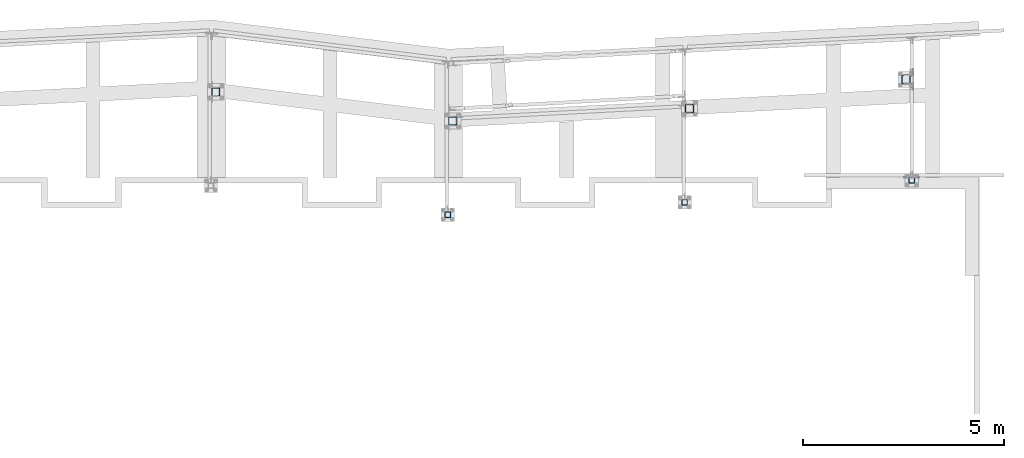
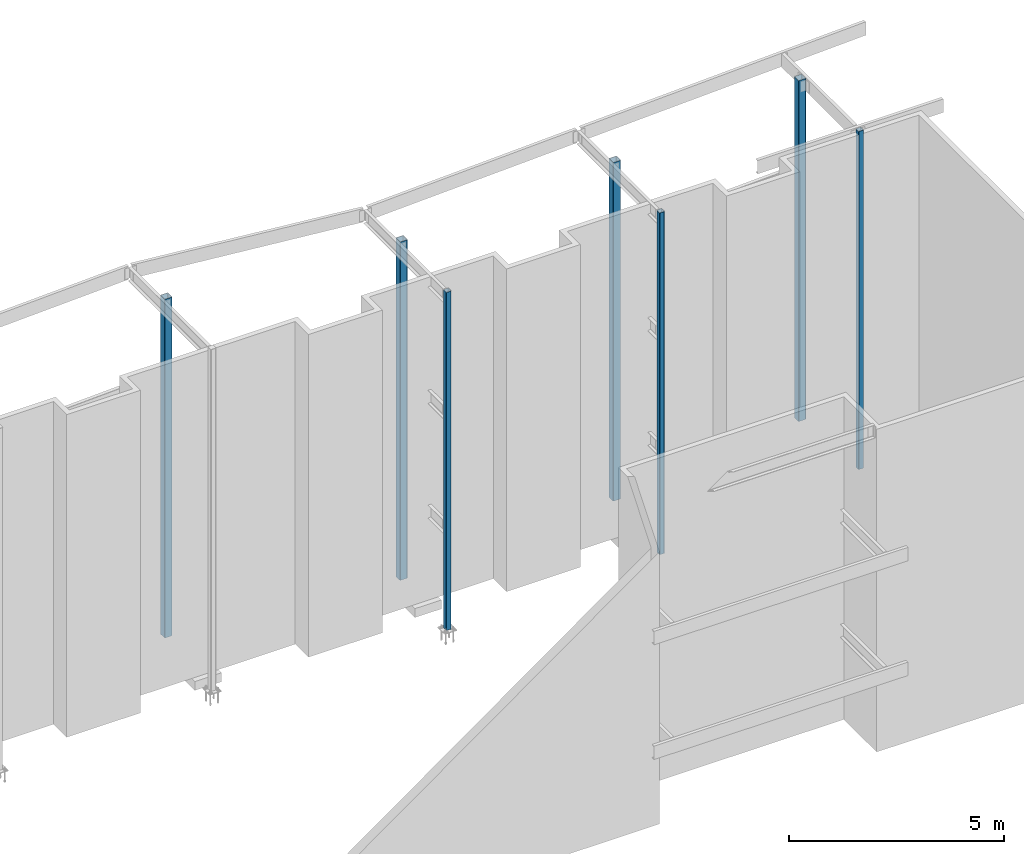
# One storey, part 2 of 89: 7 columns.
"""IFC4 building model written with IfcOpenShell, lengths in feet."""

from ifc_helpers import new_model, entity, si_unit, converted_unit, derived_unit, direction, frame, origin, place, context, subcontext, project, spatial, polyline, outline, extrude, boolean, source, transform, mapped, material, type_object, type_shapes, element, save


model = new_model("IFC4")

# Units and contexts
model_context = context("Model", 3, precision=0.0001, world=origin(), true_north=direction((6.12303176911189e-17, 1.0)))
body_context = subcontext(model_context, "Body", "Model", "MODEL_VIEW")
ifc_project = project(units=[converted_unit("LENGTHUNIT", "FOOT", entity("IfcRatioMeasure", 0.3048), si_unit("LENGTHUNIT", "METRE"), dimensions=[1, 0, 0, 0, 0, 0, 0]), converted_unit("AREAUNIT", "SQUARE FOOT", entity("IfcRatioMeasure", 0.09290304), si_unit("AREAUNIT", "SQUARE_METRE"), dimensions=[2, 0, 0, 0, 0, 0, 0]), converted_unit("VOLUMEUNIT", "CUBIC FOOT", entity("IfcRatioMeasure", 0.028316846592), si_unit("VOLUMEUNIT", "CUBIC_METRE"), dimensions=[3, 0, 0, 0, 0, 0, 0]), si_unit("PLANEANGLEUNIT", "RADIAN"), si_unit("MASSUNIT", "GRAM", prefix="KILO"), derived_unit("MASSDENSITYUNIT", [(si_unit("MASSUNIT", "GRAM", prefix="KILO"), 1), (si_unit("LENGTHUNIT", "METRE"), -3)]), derived_unit("MOMENTOFINERTIAUNIT", [(si_unit("LENGTHUNIT", "METRE"), 4)]), si_unit("TIMEUNIT", "SECOND"), si_unit("FREQUENCYUNIT", "HERTZ"), si_unit("THERMODYNAMICTEMPERATUREUNIT", "DEGREE_CELSIUS"), derived_unit("THERMALTRANSMITTANCEUNIT", [(si_unit("MASSUNIT", "GRAM", prefix="KILO"), 1), (si_unit("THERMODYNAMICTEMPERATUREUNIT", "KELVIN"), -1), (si_unit("TIMEUNIT", "SECOND"), -3)]), derived_unit("VOLUMETRICFLOWRATEUNIT", [(si_unit("LENGTHUNIT", "METRE"), 3), (si_unit("TIMEUNIT", "SECOND"), -1)]), si_unit("ELECTRICCURRENTUNIT", "AMPERE"), si_unit("ELECTRICVOLTAGEUNIT", "VOLT"), si_unit("POWERUNIT", "WATT"), si_unit("FORCEUNIT", "NEWTON"), si_unit("ILLUMINANCEUNIT", "LUX"), si_unit("LUMINOUSFLUXUNIT", "LUMEN"), si_unit("LUMINOUSINTENSITYUNIT", "CANDELA"), derived_unit("USERDEFINED", [(si_unit("MASSUNIT", "GRAM", prefix="KILO"), -1), (si_unit("LENGTHUNIT", "METRE"), -2), (si_unit("TIMEUNIT", "SECOND"), 3), (si_unit("LUMINOUSFLUXUNIT", "LUMEN"), 1)]), derived_unit("LINEARVELOCITYUNIT", [(si_unit("LENGTHUNIT", "METRE"), 1), (si_unit("TIMEUNIT", "SECOND"), -1)]), si_unit("PRESSUREUNIT", "PASCAL"), derived_unit("USERDEFINED", [(si_unit("LENGTHUNIT", "METRE"), -2), (si_unit("MASSUNIT", "GRAM", prefix="KILO"), 1), (si_unit("TIMEUNIT", "SECOND"), -2)]), derived_unit("LINEARFORCEUNIT", [(si_unit("MASSUNIT", "GRAM", prefix="KILO"), 1), (si_unit("LENGTHUNIT", "METRE"), 1), (si_unit("TIMEUNIT", "SECOND"), -2), (si_unit("LENGTHUNIT", "METRE"), -1)]), derived_unit("PLANARFORCEUNIT", [(si_unit("MASSUNIT", "GRAM", prefix="KILO"), 1), (si_unit("LENGTHUNIT", "METRE"), 1), (si_unit("TIMEUNIT", "SECOND"), -2), (si_unit("LENGTHUNIT", "METRE"), -2)])], contexts=[model_context])

# Site, building, storey
site_placement = place(None, origin())
site = spatial("IfcSite", under=ifc_project, at=site_placement, CompositionType="ELEMENT")
building_placement = place(site_placement, frame((-472.238160486, -49.138065117, 0.0)))
building = spatial("IfcBuilding", under=site, at=building_placement, CompositionType="ELEMENT")
storey_placement = place(building_placement, origin())
storey = spatial("IfcBuildingStorey", under=building, at=storey_placement, Name="Level 1", CompositionType="ELEMENT", Elevation=0.0)

# Columns
ifc_material = material(Name="Color 7719", Category="Materials")
column_type_1 = type_object("IfcColumnType", Name="hss15", PredefinedType="COLUMN")
shared_shape_1 = source(origin(), body_context, "Body", "CSG", [
    boolean("DIFFERENCE", extrude(outline(polyline([(-0.166666666666629, -0.229166666666686), (0.166666666666629, -0.229166666666686), (0.190584381189524, -0.224409137448617), (0.210860840490795, -0.210860840490852), (0.224409137448674, -0.190584381189467), (0.229166666666629, -0.166666666666686), (0.229166666666629, 0.166666666666686), (0.224409137448674, 0.190584381189467), (0.210860840490795, 0.210860840490852), (0.190584381189524, 0.224409137448617), (0.166666666666629, 0.229166666666686), (-0.166666666666629, 0.229166666666686), (-0.190584381189524, 0.224409137448617), (-0.210860840490795, 0.210860840490852), (-0.224409137448674, 0.190584381189467), (-0.229166666666629, 0.166666666666686), (-0.229166666666629, -0.166666666666686), (-0.224409137448674, -0.190584381189467), (-0.210860840490795, -0.210860840490852), (-0.190584381189524, -0.224409137448617), (-0.166666666666629, -0.229166666666686)])), frame((288.4375, 1004.96354166667, -0.375), z_axis=(0.0, 0.0, 1.0), x_axis=(0.0, -1.0, 0.0)), (0.0, 0.0, 1.0), 31.4375), extrude(outline(polyline([(-0.166666666666629, -0.197916666666742), (0.166666666666629, -0.197916666666742), (0.178625523928076, -0.195537902057708), (0.188763753578769, -0.188763753578826), (0.195537902057595, -0.178625523928133), (0.197916666666629, -0.166666666666742), (0.197916666666629, 0.166666666666629), (0.195537902057595, 0.178625523928019), (0.188763753578769, 0.188763753578712), (0.178625523928076, 0.195537902057595), (0.166666666666629, 0.197916666666629), (-0.166666666666629, 0.197916666666629), (-0.178625523928076, 0.195537902057595), (-0.188763753578769, 0.188763753578712), (-0.195537902057595, 0.178625523928019), (-0.197916666666629, 0.166666666666629), (-0.197916666666629, -0.166666666666742), (-0.195537902057595, -0.178625523928133), (-0.188763753578769, -0.188763753578826), (-0.178625523928076, -0.195537902057708), (-0.166666666666629, -0.197916666666742)])), frame((288.4375, 1004.96354166667, 31.0625), z_axis=(0.0, 0.0, -1.0), x_axis=(0.0, -1.0, 0.0)), (0.0, 0.0, 1.0), 31.4375)),
])
type_shapes(column_type_1, [shared_shape_1])
column_1_placement = place(building_placement, origin())
element("IfcColumn", 1, at=column_1_placement, inside=storey, type_object=column_type_1, material=ifc_material, Name="hss15 5021:hss15 5021", ObjectType="hss15 5021:hss15 5021", PredefinedType="COLUMN", context=body_context, shape_type="MappedRepresentation", body=[
    mapped(shared_shape_1, transform((0.0, 0.0, 0.0), scale=1.0)),
])
column_type_2 = type_object("IfcColumnType", Name="hss16", PredefinedType="COLUMN")
shared_shape_2 = source(origin(), body_context, "Body", "CSG", [
    boolean("DIFFERENCE", extrude(outline(polyline([(-0.166666666666629, -0.229166666666742), (0.166666666666629, -0.229166666666742), (0.190584381189524, -0.224409137448674), (0.210860840490795, -0.210860840490909), (0.224409137448674, -0.190584381189524), (0.229166666666629, -0.166666666666742), (0.229166666666629, 0.166666666666629), (0.224409137448674, 0.19058438118941), (0.210860840490795, 0.210860840490795), (0.190584381189524, 0.224409137448561), (0.166666666666629, 0.229166666666629), (-0.166666666666629, 0.229166666666629), (-0.190584381189524, 0.224409137448561), (-0.210860840490795, 0.210860840490795), (-0.224409137448674, 0.19058438118941), (-0.229166666666629, 0.166666666666629), (-0.229166666666629, -0.166666666666742), (-0.224409137448674, -0.190584381189524), (-0.210860840490795, -0.210860840490909), (-0.190584381189524, -0.224409137448674), (-0.166666666666629, -0.229166666666742)])), frame((307.770833333333, 1005.97916666667, -0.708333333333334), z_axis=(0.0, 0.0, 1.0), x_axis=(0.0, -1.0, 0.0)), (0.0, 0.0, 1.0), 31.7708333333333), extrude(outline(polyline([(-0.166666666666629, -0.197916666666742), (0.166666666666629, -0.197916666666742), (0.178625523928076, -0.195537902057708), (0.188763753578769, -0.188763753578826), (0.195537902057595, -0.178625523928133), (0.197916666666629, -0.166666666666742), (0.197916666666629, 0.166666666666629), (0.195537902057595, 0.178625523928019), (0.188763753578769, 0.188763753578712), (0.178625523928076, 0.195537902057595), (0.166666666666629, 0.197916666666629), (-0.166666666666629, 0.197916666666629), (-0.178625523928076, 0.195537902057595), (-0.188763753578769, 0.188763753578712), (-0.195537902057595, 0.178625523928019), (-0.197916666666629, 0.166666666666629), (-0.197916666666629, -0.166666666666742), (-0.195537902057595, -0.178625523928133), (-0.188763753578769, -0.188763753578826), (-0.178625523928076, -0.195537902057708), (-0.166666666666629, -0.197916666666742)])), frame((307.770833333333, 1005.97916666667, 31.0625), z_axis=(0.0, 0.0, -1.0), x_axis=(0.0, -1.0, 0.0)), (0.0, 0.0, 1.0), 31.7708333333333)),
])
type_shapes(column_type_2, [shared_shape_2])
column_2_placement = place(building_placement, origin())
element("IfcColumn", 2, at=column_2_placement, inside=storey, type_object=column_type_2, material=ifc_material, Name="hss16 5022:hss16 5022", ObjectType="hss16 5022:hss16 5022", PredefinedType="COLUMN", context=body_context, shape_type="MappedRepresentation", body=[
    mapped(shared_shape_2, transform((0.0, 0.0, 0.0), scale=1.0)),
])
column_type_3 = type_object("IfcColumnType", Name="hss15", PredefinedType="COLUMN")
shared_shape_3 = source(origin(), body_context, "Body", "CSG", [
    boolean("DIFFERENCE", extrude(outline(polyline([(-0.166666666666515, -0.229166666666686), (0.166666666666742, -0.229166666666686), (0.190584381189638, -0.224409137448617), (0.210860840490909, -0.210860840490852), (0.224409137448788, -0.190584381189467), (0.229166666666742, -0.166666666666686), (0.229166666666742, 0.166666666666686), (0.224409137448788, 0.190584381189467), (0.210860840490909, 0.210860840490852), (0.190584381189638, 0.224409137448617), (0.166666666666742, 0.229166666666686), (-0.166666666666515, 0.229166666666686), (-0.19058438118941, 0.224409137448617), (-0.210860840490682, 0.210860840490852), (-0.224409137448561, 0.190584381189467), (-0.229166666666515, 0.166666666666686), (-0.229166666666515, -0.166666666666686), (-0.224409137448561, -0.190584381189467), (-0.210860840490682, -0.210860840490852), (-0.19058438118941, -0.224409137448617), (-0.166666666666515, -0.229166666666686)])), frame((326.307291666667, 1007.77083333333, -0.375), z_axis=(0.0, 0.0, 1.0), x_axis=(0.0, -1.0, 0.0)), (0.0, 0.0, 1.0), 31.4375), extrude(outline(polyline([(-0.166666666666856, -0.197916666666686), (0.166666666666401, -0.197916666666686), (0.178625523927849, -0.195537902057652), (0.188763753578542, -0.188763753578769), (0.195537902057367, -0.178625523928076), (0.197916666666401, -0.166666666666686), (0.197916666666401, 0.166666666666686), (0.195537902057367, 0.178625523928076), (0.188763753578542, 0.188763753578769), (0.178625523927849, 0.195537902057652), (0.166666666666401, 0.197916666666686), (-0.166666666666856, 0.197916666666686), (-0.178625523928304, 0.195537902057652), (-0.188763753578996, 0.188763753578769), (-0.195537902057822, 0.178625523928076), (-0.197916666666856, 0.166666666666686), (-0.197916666666856, -0.166666666666686), (-0.195537902057822, -0.178625523928076), (-0.188763753578996, -0.188763753578769), (-0.178625523928304, -0.195537902057652), (-0.166666666666856, -0.197916666666686)])), frame((326.307291666667, 1007.77083333333, 31.0625), z_axis=(0.0, 0.0, -1.0), x_axis=(0.0, -1.0, 0.0)), (0.0, 0.0, 1.0), 31.4375)),
])
type_shapes(column_type_3, [shared_shape_3])
column_3_placement = place(building_placement, origin())
element("IfcColumn", 3, at=column_3_placement, inside=storey, type_object=column_type_3, material=ifc_material, Name="hss15 5023:hss15 5023", ObjectType="hss15 5023:hss15 5023", PredefinedType="COLUMN", context=body_context, shape_type="MappedRepresentation", body=[
    mapped(shared_shape_3, transform((0.0, 0.0, 0.0), scale=1.0)),
])
column_type_4 = type_object("IfcColumnType", Name="hss19", PredefinedType="COLUMN")
shared_shape_4 = source(origin(), body_context, "Body", "CSG", [
    boolean("DIFFERENCE", extrude(outline(polyline([(-0.270833333333371, -0.333333333333371), (0.270833333333371, -0.333333333333371), (0.294751047856153, -0.32857580411536), (0.315027507157538, -0.315027507157538), (0.328575804115303, -0.294751047856209), (0.333333333333371, -0.270833333333371), (0.333333333333371, 0.270833333333258), (0.328575804115303, 0.294751047856096), (0.315027507157538, 0.315027507157424), (0.294751047856153, 0.328575804115246), (0.270833333333371, 0.333333333333258), (-0.270833333333371, 0.333333333333258), (-0.294751047856153, 0.328575804115246), (-0.315027507157538, 0.315027507157424), (-0.328575804115303, 0.294751047856096), (-0.333333333333371, 0.270833333333258), (-0.333333333333371, -0.270833333333371), (-0.328575804115303, -0.294751047856209), (-0.315027507157538, -0.315027507157538), (-0.294751047856153, -0.32857580411536), (-0.270833333333371, -0.333333333333371)])), frame((325.833333333333, 1016.0, -0.625), z_axis=(0.0, 0.0, 1.0), x_axis=(0.0, -1.0, 0.0)), (0.0, 0.0, 1.0), 31.6875), extrude(outline(polyline([(-0.270833333333599, -0.302083333333258), (0.270833333333144, -0.302083333333258), (0.282792190594478, -0.29970456872428), (0.29293042024517, -0.292930420245341), (0.29970456872411, -0.282792190594705), (0.302083333333144, -0.270833333333258), (0.302083333333144, 0.270833333333371), (0.29970456872411, 0.282792190594819), (0.29293042024517, 0.292930420245455), (0.282792190594478, 0.299704568724394), (0.270833333333144, 0.302083333333371), (-0.270833333333599, 0.302083333333371), (-0.282792190594932, 0.299704568724394), (-0.292930420245625, 0.292930420245455), (-0.299704568724565, 0.282792190594819), (-0.302083333333599, 0.270833333333371), (-0.302083333333599, -0.270833333333258), (-0.299704568724565, -0.282792190594705), (-0.292930420245625, -0.292930420245341), (-0.282792190594932, -0.29970456872428), (-0.270833333333599, -0.302083333333258)])), frame((325.833333333333, 1016.0, 31.0625), z_axis=(0.0, 0.0, -1.0), x_axis=(0.0, -1.0, 0.0)), (0.0, 0.0, 1.0), 31.6875)),
])
type_shapes(column_type_4, [shared_shape_4])
column_4_placement = place(building_placement, origin())
element("IfcColumn", 4, at=column_4_placement, inside=storey, type_object=column_type_4, material=ifc_material, Name="hss19:hss19", ObjectType="hss19:hss19", PredefinedType="COLUMN", context=body_context, shape_type="MappedRepresentation", body=[
    mapped(shared_shape_4, transform((0.0, 0.0, 0.0), scale=1.0)),
])
column_type_5 = type_object("IfcColumnType", Name="hss20", PredefinedType="COLUMN")
shared_shape_5 = source(origin(), body_context, "Body", "CSG", [
    boolean("DIFFERENCE", extrude(outline(polyline([(-0.270833333333144, -0.333333333333314), (0.270833333333599, -0.333333333333314), (0.29475104785638, -0.328575804115303), (0.315027507157765, -0.315027507157481), (0.32857580411553, -0.294751047856153), (0.333333333333599, -0.270833333333314), (0.333333333333599, 0.270833333333314), (0.32857580411553, 0.294751047856153), (0.315027507157765, 0.315027507157481), (0.29475104785638, 0.328575804115303), (0.270833333333599, 0.333333333333314), (-0.270833333333144, 0.333333333333314), (-0.294751047855925, 0.328575804115303), (-0.315027507157311, 0.315027507157481), (-0.328575804115076, 0.294751047856153), (-0.333333333333144, 0.270833333333314), (-0.333333333333144, -0.270833333333314), (-0.328575804115076, -0.294751047856153), (-0.315027507157311, -0.315027507157481), (-0.294751047855925, -0.328575804115303), (-0.270833333333144, -0.333333333333314)])), frame((308.166666666667, 1013.63541666667, -0.416666666666668), z_axis=(0.0, 0.0, 1.0), x_axis=(0.0, -1.0, 0.0)), (0.0, 0.0, 1.0), 31.4791666666667), extrude(outline(polyline([(-0.270833333333371, -0.302083333333314), (0.270833333333371, -0.302083333333314), (0.282792190594705, -0.299704568724337), (0.292930420245398, -0.292930420245398), (0.299704568724337, -0.282792190594762), (0.302083333333371, -0.270833333333314), (0.302083333333371, 0.270833333333314), (0.299704568724337, 0.282792190594762), (0.292930420245398, 0.292930420245398), (0.282792190594705, 0.299704568724337), (0.270833333333371, 0.302083333333314), (-0.270833333333371, 0.302083333333314), (-0.282792190594705, 0.299704568724337), (-0.292930420245398, 0.292930420245398), (-0.299704568724337, 0.282792190594762), (-0.302083333333371, 0.270833333333314), (-0.302083333333371, -0.270833333333314), (-0.299704568724337, -0.282792190594762), (-0.292930420245398, -0.292930420245398), (-0.282792190594705, -0.299704568724337), (-0.270833333333371, -0.302083333333314)])), frame((308.166666666667, 1013.63541666667, 31.0625), z_axis=(0.0, 0.0, -1.0), x_axis=(0.0, -1.0, 0.0)), (0.0, 0.0, 1.0), 31.4791666666667)),
])
type_shapes(column_type_5, [shared_shape_5])
column_5_placement = place(building_placement, origin())
element("IfcColumn", 5, at=column_5_placement, inside=storey, type_object=column_type_5, material=ifc_material, Name="hss20:hss20", ObjectType="hss20:hss20", PredefinedType="COLUMN", context=body_context, shape_type="MappedRepresentation", body=[
    mapped(shared_shape_5, transform((0.0, 0.0, 0.0), scale=1.0)),
])
column_type_6 = type_object("IfcColumnType", Name="hss21", PredefinedType="COLUMN")
shared_shape_6 = source(origin(), body_context, "Body", "CSG", [
    boolean("DIFFERENCE", extrude(outline(polyline([(-0.270833333333144, -0.333333333333314), (0.270833333333599, -0.333333333333314), (0.29475104785638, -0.328575804115303), (0.315027507157765, -0.315027507157481), (0.32857580411553, -0.294751047856153), (0.333333333333599, -0.270833333333314), (0.333333333333599, 0.270833333333314), (0.32857580411553, 0.294751047856153), (0.315027507157765, 0.315027507157481), (0.29475104785638, 0.328575804115303), (0.270833333333599, 0.333333333333314), (-0.270833333333144, 0.333333333333314), (-0.294751047855925, 0.328575804115303), (-0.315027507157311, 0.315027507157481), (-0.328575804115076, 0.294751047856153), (-0.333333333333144, 0.270833333333314), (-0.333333333333144, -0.270833333333314), (-0.328575804115076, -0.294751047856153), (-0.315027507157311, -0.315027507157481), (-0.294751047855925, -0.328575804115303), (-0.270833333333144, -0.333333333333314)])), frame((288.833333333333, 1012.61979166667, -0.395833333333334), z_axis=(0.0, 0.0, 1.0), x_axis=(0.0, -1.0, 0.0)), (0.0, 0.0, 1.0), 31.4583333333333), extrude(outline(polyline([(-0.270833333333371, -0.302083333333258), (0.270833333333371, -0.302083333333258), (0.282792190594705, -0.29970456872428), (0.292930420245398, -0.292930420245341), (0.299704568724337, -0.282792190594705), (0.302083333333371, -0.270833333333258), (0.302083333333371, 0.270833333333371), (0.299704568724337, 0.282792190594819), (0.292930420245398, 0.292930420245455), (0.282792190594705, 0.299704568724394), (0.270833333333371, 0.302083333333371), (-0.270833333333371, 0.302083333333371), (-0.282792190594705, 0.299704568724394), (-0.292930420245398, 0.292930420245455), (-0.299704568724337, 0.282792190594819), (-0.302083333333371, 0.270833333333371), (-0.302083333333371, -0.270833333333258), (-0.299704568724337, -0.282792190594705), (-0.292930420245398, -0.292930420245341), (-0.282792190594705, -0.29970456872428), (-0.270833333333371, -0.302083333333258)])), frame((288.833333333333, 1012.61979166667, 31.0625), z_axis=(0.0, 0.0, -1.0), x_axis=(0.0, -1.0, 0.0)), (0.0, 0.0, 1.0), 31.4583333333333)),
])
type_shapes(column_type_6, [shared_shape_6])
column_6_placement = place(building_placement, origin())
element("IfcColumn", 6, at=column_6_placement, inside=storey, type_object=column_type_6, material=ifc_material, Name="hss21:hss21", ObjectType="hss21:hss21", PredefinedType="COLUMN", context=body_context, shape_type="MappedRepresentation", body=[
    mapped(shared_shape_6, transform((0.0, 0.0, 0.0), scale=1.0)),
])
column_type_7 = type_object("IfcColumnType", Name="hss20", PredefinedType="COLUMN")
shared_shape_7 = source(origin(), body_context, "Body", "CSG", [
    boolean("DIFFERENCE", extrude(outline(polyline([(-0.270833333333144, -0.333333333333314), (0.270833333333599, -0.333333333333314), (0.29475104785638, -0.328575804115303), (0.315027507157765, -0.315027507157481), (0.32857580411553, -0.294751047856153), (0.333333333333599, -0.270833333333314), (0.333333333333599, 0.270833333333314), (0.32857580411553, 0.294751047856153), (0.315027507157765, 0.315027507157481), (0.29475104785638, 0.328575804115303), (0.270833333333599, 0.333333333333314), (-0.270833333333144, 0.333333333333314), (-0.294751047855925, 0.328575804115303), (-0.315027507157311, 0.315027507157481), (-0.328575804115076, 0.294751047856153), (-0.333333333333144, 0.270833333333314), (-0.333333333333144, -0.270833333333314), (-0.328575804115076, -0.294751047856153), (-0.315027507157311, -0.315027507157481), (-0.294751047855925, -0.328575804115303), (-0.270833333333144, -0.333333333333314)])), frame((269.5, 1014.99479166667, -0.416666666666668), z_axis=(0.0, 0.0, 1.0), x_axis=(0.0, -1.0, 0.0)), (0.0, 0.0, 1.0), 31.4791666666667), extrude(outline(polyline([(-0.270833333333371, -0.302083333333314), (0.270833333333371, -0.302083333333314), (0.282792190594705, -0.299704568724337), (0.292930420245398, -0.292930420245398), (0.299704568724337, -0.282792190594762), (0.302083333333371, -0.270833333333314), (0.302083333333371, 0.270833333333314), (0.299704568724337, 0.282792190594762), (0.292930420245398, 0.292930420245398), (0.282792190594705, 0.299704568724337), (0.270833333333371, 0.302083333333314), (-0.270833333333371, 0.302083333333314), (-0.282792190594705, 0.299704568724337), (-0.292930420245398, 0.292930420245398), (-0.299704568724337, 0.282792190594762), (-0.302083333333371, 0.270833333333314), (-0.302083333333371, -0.270833333333314), (-0.299704568724337, -0.282792190594762), (-0.292930420245398, -0.292930420245398), (-0.282792190594705, -0.299704568724337), (-0.270833333333371, -0.302083333333314)])), frame((269.5, 1014.99479166667, 31.0625), z_axis=(0.0, 0.0, -1.0), x_axis=(0.0, -1.0, 0.0)), (0.0, 0.0, 1.0), 31.4791666666667)),
])
type_shapes(column_type_7, [shared_shape_7])
column_7_placement = place(building_placement, origin())
element("IfcColumn", 7, at=column_7_placement, inside=storey, type_object=column_type_7, material=ifc_material, Name="hss20 5027:hss20 5027", ObjectType="hss20 5027:hss20 5027", PredefinedType="COLUMN", context=body_context, shape_type="MappedRepresentation", body=[
    mapped(shared_shape_7, transform((0.0, 0.0, 0.0), scale=1.0)),
])

save(model, "model.ifc")
